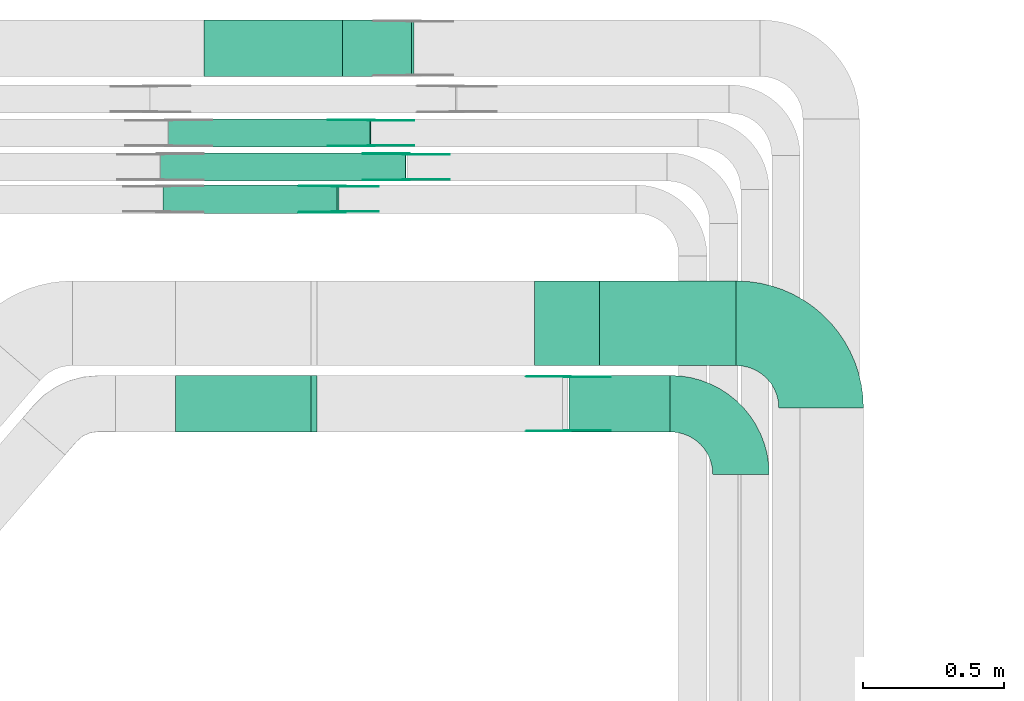
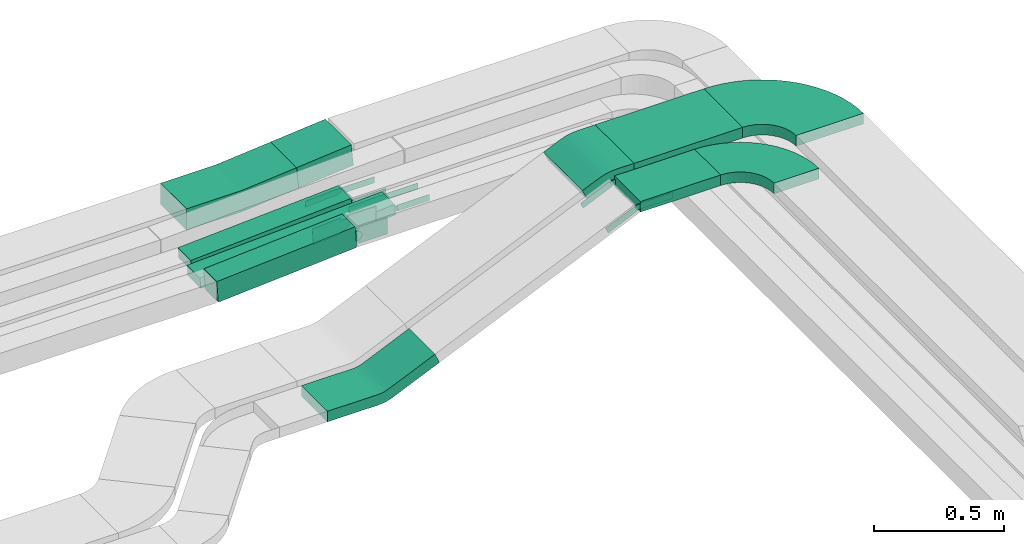
# One storey, part 23 of 31: 21 flow fittings, 6 flow segments.
"""IFC2X3 building model written with IfcOpenShell, lengths in millimetres."""

from ifc_helpers import new_model, entity, si_unit, converted_unit, derived_unit, direction, frame, frame_2d, origin, origin_2d_with_axis, place, context, subcontext, project, spatial, polyline, circle_curve, parameter, trimmed, segment, composite_curve, rectangle, outline, extrude, source, transform, mapped, material, type_object, type_shapes, element, save


model = new_model("IFC2X3")

# Units and contexts
model_context = context("Model", 3, precision=0.01, world=origin(), true_north=direction((6.12303176911189e-17, 1.0)))
body_context = subcontext(model_context, "Body", "Model", "MODEL_VIEW")
ifc_project = project(units=[si_unit("LENGTHUNIT", "METRE", prefix="MILLI"), si_unit("AREAUNIT", "SQUARE_METRE"), si_unit("VOLUMEUNIT", "CUBIC_METRE"), converted_unit("PLANEANGLEUNIT", "DEGREE", entity("IfcRatioMeasure", 0.0174532925199433), si_unit("PLANEANGLEUNIT", "RADIAN"), dimensions=[0, 0, 0, 0, 0, 0, 0]), si_unit("MASSUNIT", "GRAM", prefix="KILO"), derived_unit("MASSDENSITYUNIT", [(si_unit("MASSUNIT", "GRAM", prefix="KILO"), 1), (si_unit("LENGTHUNIT", "METRE"), -3)]), derived_unit("MOMENTOFINERTIAUNIT", [(si_unit("LENGTHUNIT", "METRE"), 4)]), si_unit("TIMEUNIT", "SECOND"), si_unit("FREQUENCYUNIT", "HERTZ"), si_unit("THERMODYNAMICTEMPERATUREUNIT", "DEGREE_CELSIUS"), derived_unit("THERMALTRANSMITTANCEUNIT", [(si_unit("MASSUNIT", "GRAM", prefix="KILO"), 1), (si_unit("THERMODYNAMICTEMPERATUREUNIT", "KELVIN"), -1), (si_unit("TIMEUNIT", "SECOND"), -3)]), derived_unit("VOLUMETRICFLOWRATEUNIT", [(si_unit("LENGTHUNIT", "METRE"), 3), (si_unit("TIMEUNIT", "SECOND"), -1)]), derived_unit("MASSFLOWRATEUNIT", [(si_unit("MASSUNIT", "GRAM", prefix="KILO"), 1), (si_unit("TIMEUNIT", "SECOND"), -1)]), derived_unit("ROTATIONALFREQUENCYUNIT", [(si_unit("TIMEUNIT", "SECOND"), -1)]), si_unit("ELECTRICCURRENTUNIT", "AMPERE"), si_unit("ELECTRICVOLTAGEUNIT", "VOLT"), si_unit("POWERUNIT", "WATT"), si_unit("FORCEUNIT", "NEWTON", prefix="KILO"), si_unit("ILLUMINANCEUNIT", "LUX"), si_unit("LUMINOUSFLUXUNIT", "LUMEN"), si_unit("LUMINOUSINTENSITYUNIT", "CANDELA"), derived_unit("USERDEFINED", [(si_unit("MASSUNIT", "GRAM", prefix="KILO"), -1), (si_unit("LENGTHUNIT", "METRE"), -2), (si_unit("TIMEUNIT", "SECOND"), 3), (si_unit("LUMINOUSFLUXUNIT", "LUMEN"), 1)]), derived_unit("LINEARVELOCITYUNIT", [(si_unit("LENGTHUNIT", "METRE"), 1), (si_unit("TIMEUNIT", "SECOND"), -1)]), si_unit("PRESSUREUNIT", "PASCAL"), derived_unit("USERDEFINED", [(si_unit("LENGTHUNIT", "METRE"), -2), (si_unit("MASSUNIT", "GRAM", prefix="KILO"), 1), (si_unit("TIMEUNIT", "SECOND"), -2)]), derived_unit("LINEARFORCEUNIT", [(si_unit("MASSUNIT", "GRAM", prefix="KILO"), 1), (si_unit("LENGTHUNIT", "METRE"), 1), (si_unit("TIMEUNIT", "SECOND"), -2), (si_unit("LENGTHUNIT", "METRE"), -1)]), derived_unit("PLANARFORCEUNIT", [(si_unit("MASSUNIT", "GRAM", prefix="KILO"), 1), (si_unit("LENGTHUNIT", "METRE"), 1), (si_unit("TIMEUNIT", "SECOND"), -2), (si_unit("LENGTHUNIT", "METRE"), -2)])], contexts=[model_context])

# Site, building, storey
site_placement = place(None, frame((0.0, -0.00077364408347762, 0.0)))
site = spatial("IfcSite", under=ifc_project, at=site_placement, CompositionType="ELEMENT")
building_placement = place(site_placement, origin())
building = spatial("IfcBuilding", under=site, at=building_placement, CompositionType="ELEMENT")
storey_placement = place(building_placement, frame((0.0, 0.0, 15900.0)))
storey = spatial("IfcBuildingStorey", under=building, at=storey_placement, CompositionType="ELEMENT", Elevation=15900.0)

# Flow segments
cable_carrier_segment_type = type_object("IfcCableCarrierSegmentType", PredefinedType="CABLETRAYSEGMENT")
flow_segment_1_placement = place(storey_placement, frame((58933.8883361973, 15999.9939089946, 2637.68567957026)))
element("IfcFlowSegment", 1, at=flow_segment_1_placement, inside=storey, type_object=cable_carrier_segment_type, context=body_context, shape_type="SweptSolid", body=[
    extrude(rectangle(XDim=100.000000000003, YDim=200.000000000002, at=frame_2d((0.0, 0.0), x_axis=(0.0, 1.0))), frame((4.52781513391335, 100.0, 49.7945668734377), z_axis=(0.995891337468723, 0.0, 0.0905563026782642), x_axis=(0.0, 1.0, 0.0)), (0.0, 0.0, 1.0), 245.232289969506),
])
flow_segment_2_placement = place(storey_placement, frame((58297.8986946774, 15514.9939089947, 2617.34283035716)))
element("IfcFlowSegment", 2, at=flow_segment_2_placement, inside=storey, type_object=cable_carrier_segment_type, context=body_context, shape_type="SweptSolid", body=[
    extrude(rectangle(XDim=100.0, YDim=99.9999999999989, at=origin_2d_with_axis()), frame((3.44293413366104, 50.0, 49.8813211989339), z_axis=(0.997626423978678, 0.0, 0.068858682673394), x_axis=(-0.068858682673394, 0.0, 0.997626423978678)), (0.0, 0.0, 1.0), 618.350729393012),
])
flow_segment_3_placement = place(storey_placement, frame((58318.1937005725, 15749.4580000518, 2617.51736519064)))
element("IfcFlowSegment", 3, at=flow_segment_3_placement, inside=storey, type_object=cable_carrier_segment_type, context=body_context, shape_type="SweptSolid", body=[
    extrude(rectangle(XDim=50.0000000000018, YDim=99.9999999999989, at=frame_2d((0.0, 0.0), x_axis=(0.0, 1.0))), frame((1.48822581376082, 50.0, 24.9556643655764), z_axis=(0.998226574623021, 0.0, 0.0595290325504308), x_axis=(0.0, 1.0, 0.0)), (0.0, 0.0, 1.0), 715.803609284785),
])
flow_segment_4_placement = place(storey_placement, frame((58289.554017831, 15629.4580000518, 2617.47740468453)))
element("IfcFlowSegment", 4, at=flow_segment_4_placement, inside=storey, type_object=cable_carrier_segment_type, context=body_context, shape_type="SweptSolid", body=[
    extrude(rectangle(XDim=49.9999999999996, YDim=99.9999999999989, at=frame_2d((0.0, 0.0), x_axis=(0.0, 1.0))), frame((1.22692797513698, 50.0, 24.9698748043255), z_axis=(0.998794992173113, 0.0, 0.0490771190058262), x_axis=(0.0, 1.0, 0.0)), (0.0, 0.0, 1.0), 869.220832372037),
])
flow_segment_5_placement = place(storey_placement, frame((59737.938729634, 14740.0255085138, 3010.0)))
element("IfcFlowSegment", 5, at=flow_segment_5_placement, inside=storey, type_object=cable_carrier_segment_type, context=body_context, shape_type="SweptSolid", body=[
    extrude(rectangle(XDim=357.878829425625, YDim=199.999999999998, at=frame_2d((0.0, -1.08002495835535e-12), x_axis=(1.0, 0.0))), frame((178.939414712821, 100.0, 0.0), z_axis=(0.0, 0.0, 1.0), x_axis=(-1.0, 0.0, 0.0)), (0.0, 0.0, 1.0), 50.0000000000016),
])
flow_segment_6_placement = place(storey_placement, frame((59845.664235863, 14975.0255085139, 3010.0)))
element("IfcFlowSegment", 6, at=flow_segment_6_placement, inside=storey, type_object=cable_carrier_segment_type, context=body_context, shape_type="SweptSolid", body=[
    extrude(rectangle(XDim=484.15332319662, YDim=300.000000000001, at=frame_2d((-4.33431068813661e-12, 1.08002495835535e-12), x_axis=(1.0, 0.0))), frame((242.076661598306, 150.0, 0.0), z_axis=(0.0, 0.0, 1.0), x_axis=(-1.0, 0.0, 0.0)), (0.0, 0.0, 1.0), 50.0000000000016),
])

# Flow fittings
ifc_material_1 = material(Name="G")
cable_carrier_fitting_type_1 = type_object("IfcCableCarrierFittingType", PredefinedType="NOTDEFINED", material=ifc_material_1)
shared_shape_1 = source(origin(), body_context, "Body", "SweptSolid", [
    extrude(outline(composite_curve([segment(trimmed(circle_curve(frame_2d((-44.5901162790698, 0.0), x_axis=(1.0, 0.0)), 12.5), [parameter(90.0000000000007)], [parameter(270.0)], True, "PARAMETER"), True, "CONTINUOUS"), segment(polyline([(-44.5901162790697, -12.5), (-33.0901162790698, -12.5)]), True, "CONTINUOUS"), segment(polyline([(-33.0901162790698, -12.5), (-31.2296511627907, -14.5)]), True, "CONTINUOUS"), segment(polyline([(-31.2296511627907, -14.5), (108.90988372093, -14.5)]), True, "CONTINUOUS"), segment(polyline([(108.90988372093, -14.5), (108.90988372093, 14.5)]), True, "CONTINUOUS"), segment(polyline([(108.90988372093, 14.5), (-31.2296511627907, 14.5)]), True, "CONTINUOUS"), segment(polyline([(-31.2296511627907, 14.5), (-33.0901162790698, 12.5)]), True, "CONTINUOUS"), segment(polyline([(-33.0901162790698, 12.5), (-44.5901162790699, 12.5)]), True, "CONTINUOUS")], self_intersect=False)), frame((44.5901162790698, 0.0, 0.0), z_axis=(0.0, 0.0, -1.0), x_axis=(1.0, 0.0, 0.0)), (0.0, 0.0, -1.0), 2.0),
])
type_shapes(cable_carrier_fitting_type_1, [shared_shape_1])
for number, where, z_axis, x_axis in (
    (7, (59036.0767428681, 15753.9980000417, 2685.19508428163), (0.0, -1.0, 0.0), (-0.998226574623013, 0.0, -0.0595290325505655)),
    (8, (59160.6643444784, 15633.9980000417, 2685.19015606757), (0.0, -1.0, 0.0), (-0.998794992173109, 0.0, -0.0490771190058922)),
    (9, (59730.8175590596, 14744.5655085037, 3035.0), (0.0, -1.0, 0.0), (-0.914695360334433, 0.0, -0.404144030987297)),
):
    element("IfcFlowFitting", number, at=place(storey_placement, frame(where, z_axis=z_axis, x_axis=x_axis)), inside=storey, type_object=cable_carrier_fitting_type_1, material=ifc_material_1, context=body_context, shape_type="MappedRepresentation", body=[
        mapped(shared_shape_1, transform((0.0, 0.0, 0.0), scale=1.0)),
    ])
cable_carrier_fitting_type_2 = type_object("IfcCableCarrierFittingType", PredefinedType="NOTDEFINED", material=ifc_material_1)
shared_shape_2 = source(origin(), body_context, "Body", "SweptSolid", [
    extrude(outline(composite_curve([segment(trimmed(circle_curve(frame_2d((-44.5901162790697, 0.0), x_axis=(1.0, 0.0)), 12.5), [parameter(90.0000000000007)], [parameter(270.0)], True, "PARAMETER"), True, "CONTINUOUS"), segment(polyline([(-44.5901162790697, -12.5), (-33.0901162790697, -12.5)]), True, "CONTINUOUS"), segment(polyline([(-33.0901162790697, -12.5), (-31.2296511627907, -14.5)]), True, "CONTINUOUS"), segment(polyline([(-31.2296511627907, -14.5), (108.90988372093, -14.5)]), True, "CONTINUOUS"), segment(polyline([(108.90988372093, -14.5), (108.90988372093, 14.5)]), True, "CONTINUOUS"), segment(polyline([(108.90988372093, 14.5), (-31.2296511627907, 14.5)]), True, "CONTINUOUS"), segment(polyline([(-31.2296511627907, 14.5), (-33.0901162790698, 12.5)]), True, "CONTINUOUS"), segment(polyline([(-33.0901162790698, 12.5), (-44.5901162790699, 12.5)]), True, "CONTINUOUS")], self_intersect=False)), frame((44.5901162790697, 0.0, 0.0)), (0.0, 0.0, 1.0), 2.0),
])
type_shapes(cable_carrier_fitting_type_2, [shared_shape_2])
for number, where, z_axis, x_axis in (
    (10, (59036.0767428681, 15844.918000062, 2685.19508428164), (0.0, 1.0, 0.0), (-0.998226574623013, 0.0, -0.0595290325505655)),
    (11, (59160.6643444784, 15724.918000062, 2685.19015606758), (0.0, 1.0, 0.0), (-0.998794992173109, 0.0, -0.0490771190058922)),
    (12, (59730.8175590596, 14935.485508524, 3035.0), (0.0, 1.0, 0.0), (-0.914695360334433, 0.0, -0.404144030987297)),
):
    element("IfcFlowFitting", number, at=place(storey_placement, frame(where, z_axis=z_axis, x_axis=x_axis)), inside=storey, type_object=cable_carrier_fitting_type_2, material=ifc_material_1, context=body_context, shape_type="MappedRepresentation", body=[
        mapped(shared_shape_2, transform((0.0, 0.0, 0.0), scale=1.0)),
    ])
cable_carrier_fitting_type_3 = type_object("IfcCableCarrierFittingType", PredefinedType="NOTDEFINED", material=ifc_material_1)
shared_shape_3 = source(origin(), body_context, "Body", "SweptSolid", [
    extrude(outline(composite_curve([segment(trimmed(circle_curve(frame_2d((-44.5901162790698, 0.0), x_axis=(1.0, 0.0)), 12.5), [parameter(90.0000000000007)], [parameter(270.0)], True, "PARAMETER"), True, "CONTINUOUS"), segment(polyline([(-44.5901162790697, -12.5), (-33.0901162790698, -12.5)]), True, "CONTINUOUS"), segment(polyline([(-33.0901162790698, -12.5), (-31.2296511627907, -14.5)]), True, "CONTINUOUS"), segment(polyline([(-31.2296511627907, -14.5), (108.90988372093, -14.5)]), True, "CONTINUOUS"), segment(polyline([(108.90988372093, -14.5), (108.90988372093, 14.5)]), True, "CONTINUOUS"), segment(polyline([(108.90988372093, 14.5), (-31.2296511627907, 14.5)]), True, "CONTINUOUS"), segment(polyline([(-31.2296511627907, 14.5), (-33.0901162790698, 12.5)]), True, "CONTINUOUS"), segment(polyline([(-33.0901162790698, 12.5), (-44.5901162790699, 12.5)]), True, "CONTINUOUS")], self_intersect=False)), frame((44.5901162790698, 0.0, 0.0), z_axis=(0.0, 0.0, -1.0), x_axis=(1.0, 0.0, 0.0)), (0.0, 0.0, -1.0), 2.0),
])
type_shapes(cable_carrier_fitting_type_3, [shared_shape_3])
for number, where, z_axis, x_axis in (
    (13, (59036.0767428681, 15842.918000062, 2685.19508428163), (0.0, 1.0, 0.0), (1.0, 0.0, 0.0)),
    (14, (59160.6643444783, 15722.918000062, 2685.19015606757), (0.0, 1.0, 0.0), (1.0, 0.0, 0.0)),
    (15, (59730.8175590596, 14933.485508524, 3035.0), (0.0, 1.0, 0.0), (1.0, 0.0, 0.0)),
):
    element("IfcFlowFitting", number, at=place(storey_placement, frame(where, z_axis=z_axis, x_axis=x_axis)), inside=storey, type_object=cable_carrier_fitting_type_3, material=ifc_material_1, context=body_context, shape_type="MappedRepresentation", body=[
        mapped(shared_shape_3, transform((0.0, 0.0, 0.0), scale=1.0)),
    ])
cable_carrier_fitting_type_4 = type_object("IfcCableCarrierFittingType", PredefinedType="NOTDEFINED", material=ifc_material_1)
shared_shape_4 = source(origin(), body_context, "Body", "SweptSolid", [
    extrude(outline(composite_curve([segment(trimmed(circle_curve(frame_2d((-44.5901162790697, 0.0), x_axis=(1.0, 0.0)), 12.5), [parameter(90.0000000000007)], [parameter(270.0)], True, "PARAMETER"), True, "CONTINUOUS"), segment(polyline([(-44.5901162790697, -12.5), (-33.0901162790697, -12.5)]), True, "CONTINUOUS"), segment(polyline([(-33.0901162790697, -12.5), (-31.2296511627907, -14.5)]), True, "CONTINUOUS"), segment(polyline([(-31.2296511627907, -14.5), (108.90988372093, -14.5)]), True, "CONTINUOUS"), segment(polyline([(108.90988372093, -14.5), (108.90988372093, 14.5)]), True, "CONTINUOUS"), segment(polyline([(108.90988372093, 14.5), (-31.2296511627907, 14.5)]), True, "CONTINUOUS"), segment(polyline([(-31.2296511627907, 14.5), (-33.0901162790698, 12.5)]), True, "CONTINUOUS"), segment(polyline([(-33.0901162790698, 12.5), (-44.5901162790699, 12.5)]), True, "CONTINUOUS")], self_intersect=False)), frame((44.5901162790697, 0.0, 0.0)), (0.0, 0.0, 1.0), 2.0),
])
type_shapes(cable_carrier_fitting_type_4, [shared_shape_4])
for number, where, z_axis, x_axis in (
    (16, (59036.0767428681, 15755.9980000417, 2685.19508428163), (0.0, -1.0, 0.0), (1.0, 0.0, 0.0)),
    (17, (59160.6643444783, 15635.9980000417, 2685.19015606757), (0.0, -1.0, 0.0), (1.0, 0.0, 0.0)),
    (18, (59730.8175590596, 14746.5655085037, 3035.0), (0.0, -1.0, 0.0), (1.0, 0.0, 0.0)),
):
    element("IfcFlowFitting", number, at=place(storey_placement, frame(where, z_axis=z_axis, x_axis=x_axis)), inside=storey, type_object=cable_carrier_fitting_type_4, material=ifc_material_1, context=body_context, shape_type="MappedRepresentation", body=[
        mapped(shared_shape_4, transform((0.0, 0.0, 0.0), scale=1.0)),
    ])
ifc_material_2 = material()
cable_carrier_fitting_type_5 = type_object("IfcCableCarrierFittingType", Name="470_DKC_S5_Variable Angle Elbow 0-45:-", PredefinedType="NOTDEFINED", material=ifc_material_2)
shared_shape_5 = source(origin(), body_context, "Body", "SweptSolid", [
    extrude(outline(composite_curve([segment(polyline([(-150.749999999996, -300.250000000003), (-149.749999999994, -300.250000000003)]), True, "CONTINUOUS"), segment(trimmed(circle_curve(frame_2d((-149.750000000002, 149.749999999997), x_axis=(0.0, -1.0)), 450.0), [parameter(0.0)], [parameter(90.0000000000001)], True, "PARAMETER"), True, "CONTINUOUS"), segment(polyline([(300.249999999997, 149.750000000005), (300.249999999997, 150.750000000004)]), True, "CONTINUOUS"), segment(polyline([(300.249999999997, 150.750000000003), (0.249999999997449, 150.750000000002)]), True, "CONTINUOUS"), segment(polyline([(0.249999999997449, 150.750000000002), (0.249999999997438, 149.75)]), True, "CONTINUOUS"), segment(trimmed(circle_curve(frame_2d((-149.750000000002, 149.749999999997), x_axis=(0.0, -1.0)), 150.0), [parameter(0.0)], [parameter(90.0000000000001)], True, "PARAMETER"), False, "CONTINUOUS"), segment(polyline([(-149.749999999999, -0.250000000002818), (-150.750000000001, -0.250000000002835)]), True, "CONTINUOUS"), segment(polyline([(-150.750000000001, -0.250000000002835), (-150.749999999996, -300.250000000003)]), True, "CONTINUOUS")], self_intersect=False)), frame((-150.249999999991, 150.249999999992, -25.0)), (0.0, 0.0, 1.0), 49.9999999999974),
])
type_shapes(cable_carrier_fitting_type_5, [shared_shape_5])
flow_fitting_1_placement = place(storey_placement, frame((60630.8175590596, 15125.0255085138, 3035.0), z_axis=(0.0, 0.0, 1.0), x_axis=(0.0, 1.0, 0.0)))
element("IfcFlowFitting", 19, at=flow_fitting_1_placement, inside=storey, type_object=cable_carrier_fitting_type_5, material=ifc_material_2, Name="470_DKC_S5_Variable Angle Elbow 0-45:-", ObjectType="470_DKC_S5_Variable Angle Elbow 0-45:-", context=body_context, shape_type="MappedRepresentation", body=[
    mapped(shared_shape_5, transform((0.0, 0.0, 0.0), scale=1.0)),
])
cable_carrier_fitting_type_6 = type_object("IfcCableCarrierFittingType", Name="470_DKC_S5_Variable Angle Elbow 0-45:-", PredefinedType="NOTDEFINED", material=ifc_material_2)
shared_shape_6 = source(origin(), body_context, "Body", "SweptSolid", [
    extrude(outline(composite_curve([segment(polyline([(-125.750000000004, -225.249999999998), (-124.750000000003, -225.249999999998)]), True, "CONTINUOUS"), segment(trimmed(circle_curve(frame_2d((-124.749999999998, 124.750000000002), x_axis=(0.0, -1.0)), 350.0), [parameter(0.0)], [parameter(90.0)], True, "PARAMETER"), True, "CONTINUOUS"), segment(polyline([(225.250000000002, 124.749999999996), (225.250000000002, 125.749999999995)]), True, "CONTINUOUS"), segment(polyline([(225.250000000002, 125.749999999995), (25.2500000000021, 125.750000000001)]), True, "CONTINUOUS"), segment(polyline([(25.2500000000021, 125.750000000001), (25.2500000000021, 124.749999999999)]), True, "CONTINUOUS"), segment(trimmed(circle_curve(frame_2d((-124.749999999998, 124.750000000002), x_axis=(0.0, -1.0)), 150.0), [parameter(0.0)], [parameter(90.0)], True, "PARAMETER"), False, "CONTINUOUS"), segment(polyline([(-124.75, -25.2499999999979), (-125.750000000001, -25.2499999999979)]), True, "CONTINUOUS"), segment(polyline([(-125.750000000001, -25.2499999999979), (-125.750000000004, -225.249999999998)]), True, "CONTINUOUS")], self_intersect=False)), frame((-125.249999999991, 125.249999999992, -25.0)), (0.0, 0.0, 1.0), 50.000000000001),
])
type_shapes(cable_carrier_fitting_type_6, [shared_shape_6])
flow_fitting_2_placement = place(storey_placement, frame((60346.8175590596, 14840.0255085138, 3035.0), z_axis=(0.0, 0.0, 1.0), x_axis=(0.0, 1.0, 0.0)))
element("IfcFlowFitting", 20, at=flow_fitting_2_placement, inside=storey, type_object=cable_carrier_fitting_type_6, material=ifc_material_2, Name="470_DKC_S5_Variable Angle Elbow 0-45:-", ObjectType="470_DKC_S5_Variable Angle Elbow 0-45:-", context=body_context, shape_type="MappedRepresentation", body=[
    mapped(shared_shape_6, transform((0.0, 0.0, 0.0), scale=1.0)),
])
cable_carrier_fitting_type_7 = type_object("IfcCableCarrierFittingType", PredefinedType="NOTDEFINED", material=ifc_material_1)
shared_shape_7 = source(origin(), body_context, "Body", "SweptSolid", [
    extrude(outline(composite_curve([segment(trimmed(circle_curve(frame_2d((-41.4651162790697, 0.0), x_axis=(1.0, 0.0)), 25.0), [parameter(90.0000000000007)], [parameter(270.0)], True, "PARAMETER"), True, "CONTINUOUS"), segment(polyline([(-41.4651162790697, -25.0), (-29.9651162790697, -25.0)]), True, "CONTINUOUS"), segment(polyline([(-29.9651162790697, -25.0), (-28.1046511627907, -38.5)]), True, "CONTINUOUS"), segment(polyline([(-28.1046511627907, -38.5), (99.5348837209303, -38.5)]), True, "CONTINUOUS"), segment(polyline([(99.5348837209303, -38.5), (99.5348837209303, 38.5)]), True, "CONTINUOUS"), segment(polyline([(99.5348837209303, 38.5), (-28.1046511627907, 38.5)]), True, "CONTINUOUS"), segment(polyline([(-28.1046511627907, 38.5), (-29.9651162790697, 25.0)]), True, "CONTINUOUS"), segment(polyline([(-29.9651162790697, 25.0), (-41.46511627907, 25.0)]), True, "CONTINUOUS")], self_intersect=False)), frame((41.4651162790697, 0.0, 0.0), z_axis=(0.0, 0.0, -1.0), x_axis=(1.0, 0.0, 0.0)), (0.0, 0.0, -1.0), 2.0),
])
type_shapes(cable_carrier_fitting_type_7, [shared_shape_7])
flow_fitting_3_placement = place(storey_placement, frame((58921.0792575167, 15519.5339089845, 2710.0), z_axis=(0.0, -1.0, 0.0), x_axis=(-0.997626423978682, 0.0, -0.0688586826733382)))
element("IfcFlowFitting", 21, at=flow_fitting_3_placement, inside=storey, type_object=cable_carrier_fitting_type_7, material=ifc_material_1, context=body_context, shape_type="MappedRepresentation", body=[
    mapped(shared_shape_7, transform((0.0, 0.0, 0.0), scale=1.0)),
])
cable_carrier_fitting_type_8 = type_object("IfcCableCarrierFittingType", PredefinedType="NOTDEFINED", material=ifc_material_1)
shared_shape_8 = source(origin(), body_context, "Body", "SweptSolid", [
    extrude(outline(composite_curve([segment(trimmed(circle_curve(frame_2d((-41.4651162790697, 0.0), x_axis=(1.0, 0.0)), 25.0), [parameter(90.0000000000007)], [parameter(270.0)], True, "PARAMETER"), True, "CONTINUOUS"), segment(polyline([(-41.4651162790697, -25.0), (-29.9651162790697, -25.0)]), True, "CONTINUOUS"), segment(polyline([(-29.9651162790697, -25.0), (-28.1046511627907, -38.5)]), True, "CONTINUOUS"), segment(polyline([(-28.1046511627907, -38.5), (99.5348837209303, -38.5)]), True, "CONTINUOUS"), segment(polyline([(99.5348837209303, -38.5), (99.5348837209303, 38.5)]), True, "CONTINUOUS"), segment(polyline([(99.5348837209303, 38.5), (-28.1046511627907, 38.5)]), True, "CONTINUOUS"), segment(polyline([(-28.1046511627907, 38.5), (-29.9651162790697, 25.0)]), True, "CONTINUOUS"), segment(polyline([(-29.9651162790697, 25.0), (-41.46511627907, 25.0)]), True, "CONTINUOUS")], self_intersect=False)), frame((41.4651162790697, 0.0, 0.0)), (0.0, 0.0, 1.0), 2.0),
])
type_shapes(cable_carrier_fitting_type_8, [shared_shape_8])
flow_fitting_4_placement = place(storey_placement, frame((58921.0792575167, 15610.4539090048, 2710.0), z_axis=(0.0, 1.0, 0.0), x_axis=(-0.997626423978682, 0.0, -0.0688586826733382)))
element("IfcFlowFitting", 22, at=flow_fitting_4_placement, inside=storey, type_object=cable_carrier_fitting_type_8, material=ifc_material_1, context=body_context, shape_type="MappedRepresentation", body=[
    mapped(shared_shape_8, transform((0.0, 0.0, 0.0), scale=1.0)),
])
cable_carrier_fitting_type_9 = type_object("IfcCableCarrierFittingType", PredefinedType="NOTDEFINED", material=ifc_material_1)
shared_shape_9 = source(origin(), body_context, "Body", "SweptSolid", [
    extrude(outline(composite_curve([segment(trimmed(circle_curve(frame_2d((-41.4651162790697, 0.0), x_axis=(1.0, 0.0)), 25.0), [parameter(90.0000000000007)], [parameter(270.0)], True, "PARAMETER"), True, "CONTINUOUS"), segment(polyline([(-41.4651162790697, -25.0), (-29.9651162790697, -25.0)]), True, "CONTINUOUS"), segment(polyline([(-29.9651162790697, -25.0), (-28.1046511627907, -38.5)]), True, "CONTINUOUS"), segment(polyline([(-28.1046511627907, -38.5), (99.5348837209303, -38.5)]), True, "CONTINUOUS"), segment(polyline([(99.5348837209303, -38.5), (99.5348837209303, 38.5)]), True, "CONTINUOUS"), segment(polyline([(99.5348837209303, 38.5), (-28.1046511627907, 38.5)]), True, "CONTINUOUS"), segment(polyline([(-28.1046511627907, 38.5), (-29.9651162790697, 25.0)]), True, "CONTINUOUS"), segment(polyline([(-29.9651162790697, 25.0), (-41.46511627907, 25.0)]), True, "CONTINUOUS")], self_intersect=False)), frame((41.4651162790697, 0.0, 0.0), z_axis=(0.0, 0.0, -1.0), x_axis=(1.0, 0.0, 0.0)), (0.0, 0.0, -1.0), 2.0),
])
type_shapes(cable_carrier_fitting_type_9, [shared_shape_9])
flow_fitting_5_placement = place(storey_placement, frame((58921.0792575167, 15608.4539090048, 2710.0), z_axis=(0.0, 1.0, 0.0), x_axis=(1.0, 0.0, 0.0)))
element("IfcFlowFitting", 23, at=flow_fitting_5_placement, inside=storey, type_object=cable_carrier_fitting_type_9, material=ifc_material_1, context=body_context, shape_type="MappedRepresentation", body=[
    mapped(shared_shape_9, transform((0.0, 0.0, 0.0), scale=1.0)),
])
cable_carrier_fitting_type_10 = type_object("IfcCableCarrierFittingType", PredefinedType="NOTDEFINED", material=ifc_material_1)
shared_shape_10 = source(origin(), body_context, "Body", "SweptSolid", [
    extrude(outline(composite_curve([segment(trimmed(circle_curve(frame_2d((-41.4651162790697, 0.0), x_axis=(1.0, 0.0)), 25.0), [parameter(90.0000000000007)], [parameter(270.0)], True, "PARAMETER"), True, "CONTINUOUS"), segment(polyline([(-41.4651162790697, -25.0), (-29.9651162790697, -25.0)]), True, "CONTINUOUS"), segment(polyline([(-29.9651162790697, -25.0), (-28.1046511627907, -38.5)]), True, "CONTINUOUS"), segment(polyline([(-28.1046511627907, -38.5), (99.5348837209303, -38.5)]), True, "CONTINUOUS"), segment(polyline([(99.5348837209303, -38.5), (99.5348837209303, 38.5)]), True, "CONTINUOUS"), segment(polyline([(99.5348837209303, 38.5), (-28.1046511627907, 38.5)]), True, "CONTINUOUS"), segment(polyline([(-28.1046511627907, 38.5), (-29.9651162790697, 25.0)]), True, "CONTINUOUS"), segment(polyline([(-29.9651162790697, 25.0), (-41.46511627907, 25.0)]), True, "CONTINUOUS")], self_intersect=False)), frame((41.4651162790697, 0.0, 0.0)), (0.0, 0.0, 1.0), 2.0),
])
type_shapes(cable_carrier_fitting_type_10, [shared_shape_10])
flow_fitting_6_placement = place(storey_placement, frame((58921.0792575167, 15521.5339089845, 2710.0), z_axis=(0.0, -1.0, 0.0), x_axis=(1.0, 0.0, 0.0)))
element("IfcFlowFitting", 24, at=flow_fitting_6_placement, inside=storey, type_object=cable_carrier_fitting_type_10, material=ifc_material_1, context=body_context, shape_type="MappedRepresentation", body=[
    mapped(shared_shape_10, transform((0.0, 0.0, 0.0), scale=1.0)),
])
cable_carrier_fitting_type_11 = type_object("IfcCableCarrierFittingType", Name="470_DKC_S5_CS 90 internal vertical angle:-", PredefinedType="NOTDEFINED", material=ifc_material_2)
shared_shape_11 = source(origin(), body_context, "Body", "SweptSolid", [
    extrude(outline(composite_curve([segment(polyline([(-247.983392623155, -55.78954394036), (-7.22359478083479, -55.78954394036)]), True, "CONTINUOUS"), segment(trimmed(circle_curve(frame_2d((-7.22359478083515, 159.210456059639), x_axis=(0.0, -1.0)), 214.999999999999), [parameter(0.0)], [parameter(5.19561157426616)], True, "PARAMETER"), True, "CONTINUOUS"), segment(polyline([(12.2460102949534, -54.906181496139), (252.016607376845, -33.1038643700154)]), True, "CONTINUOUS"), segment(polyline([(252.016607376845, -33.1038643700154), (242.960977109036, 66.4852693768588)]), True, "CONTINUOUS"), segment(polyline([(242.960977109037, 66.4852693768588), (3.19038002714467, 44.6829522507353)]), True, "CONTINUOUS"), segment(trimmed(circle_curve(frame_2d((-7.22359478083515, 159.210456059639), x_axis=(0.0, -1.0)), 114.999999999999), [parameter(0.0)], [parameter(5.19561157426616)], True, "PARAMETER"), False, "CONTINUOUS"), segment(polyline([(-7.22359478083478, 44.2104560596403), (-247.983392623155, 44.2104560596403)]), True, "CONTINUOUS"), segment(polyline([(-247.983392623155, 44.2104560596403), (-247.983392623155, -55.78954394036)]), True, "CONTINUOUS")], self_intersect=False)), frame((-0.262679477369824, 5.78954394035265, -100.0)), (0.0, 0.0, 1.0), 200.0),
])
type_shapes(cable_carrier_fitting_type_11, [shared_shape_11])
flow_fitting_7_placement = place(storey_placement, frame((58691.1900385657, 16099.9939089946, 2665.0), z_axis=(0.0, -1.0, 0.0), x_axis=(1.0, 0.0, 0.0)))
element("IfcFlowFitting", 25, at=flow_fitting_7_placement, inside=storey, type_object=cable_carrier_fitting_type_11, material=ifc_material_2, Name="470_DKC_S5_CS 90 internal vertical angle:-", ObjectType="470_DKC_S5_CS 90 internal vertical angle:-", context=body_context, shape_type="MappedRepresentation", body=[
    mapped(shared_shape_11, transform((0.0, 0.0, 0.0), scale=1.0)),
])
cable_carrier_fitting_type_12 = type_object("IfcCableCarrierFittingType", Name="470_DKC_S5_CD 90 external vertical angle:-", PredefinedType="NOTDEFINED", material=ifc_material_2)
shared_shape_12 = source(origin(), body_context, "Body", "SweptSolid", [
    extrude(outline(composite_curve([segment(polyline([(-111.654704576314, -40.1224661133865), (-31.635377592761, -40.1224661133865)]), True, "CONTINUOUS"), segment(trimmed(circle_curve(frame_2d((-31.6353775927612, 149.877533886612), x_axis=(0.0, -1.0)), 189.999999999999), [parameter(0.0)], [parameter(23.8374988354048)], True, "PARAMETER"), True, "CONTINUOUS"), segment(polyline([(45.1519882947282, -23.9145845769716), (118.345295423686, 8.42474878701124)]), True, "CONTINUOUS"), segment(polyline([(118.345295423686, 8.42474878701124), (98.1380938743463, 54.1595168037444)]), True, "CONTINUOUS"), segment(polyline([(98.1380938743463, 54.1595168037444), (24.9447867453887, 21.8201834397615)]), True, "CONTINUOUS"), segment(trimmed(circle_curve(frame_2d((-31.6353775927612, 149.877533886612), x_axis=(0.0, -1.0)), 139.999999999999), [parameter(0.0)], [parameter(23.8374988354048)], True, "PARAMETER"), False, "CONTINUOUS"), segment(polyline([(-31.635377592761, 9.87753388661379), (-111.654704576314, 9.87753388661378)]), True, "CONTINUOUS"), segment(polyline([(-111.654704576314, 9.87753388661378), (-111.654704576314, -40.1224661133865)]), True, "CONTINUOUS")], self_intersect=False)), frame((-3.19197222708058, 15.1224661133793, -150.0)), (0.0, 0.0, 1.0), 300.0),
])
type_shapes(cable_carrier_fitting_type_12, [shared_shape_12])
flow_fitting_8_placement = place(storey_placement, frame((59730.8175590596, 15125.0255085139, 3035.0), z_axis=(0.0, -1.0, 0.0), x_axis=(-1.0, 0.0, 0.0)))
element("IfcFlowFitting", 26, at=flow_fitting_8_placement, inside=storey, type_object=cable_carrier_fitting_type_12, material=ifc_material_2, Name="470_DKC_S5_CD 90 external vertical angle:-", ObjectType="470_DKC_S5_CD 90 external vertical angle:-", context=body_context, shape_type="MappedRepresentation", body=[
    mapped(shared_shape_12, transform((0.0, 0.0, 0.0), scale=1.0)),
])
cable_carrier_fitting_type_13 = type_object("IfcCableCarrierFittingType", Name="470_DKC_S5_CS 90 internal vertical angle:-", PredefinedType="NOTDEFINED", material=ifc_material_2)
shared_shape_13 = source(origin(), body_context, "Body", "SweptSolid", [
    extrude(outline(composite_curve([segment(polyline([(-249.7745398812, -53.8368643145496), (-23.4637419005688, -53.8368643145496)]), True, "CONTINUOUS"), segment(trimmed(circle_curve(frame_2d((-23.4637419005691, 111.163135685449), x_axis=(0.0, -1.0)), 164.999999999999), [parameter(0.0)], [parameter(23.8374988354359)], True, "PARAMETER"), True, "CONTINUOUS"), segment(polyline([(43.2200232123325, -39.761598769732), (250.2254601188, 51.7005593821088)]), True, "CONTINUOUS"), segment(polyline([(250.2254601188, 51.7005593821088), (230.018258569436, 97.435327398831)]), True, "CONTINUOUS"), segment(polyline([(230.018258569436, 97.435327398831), (23.0128216629682, 5.97316924699014)]), True, "CONTINUOUS"), segment(trimmed(circle_curve(frame_2d((-23.4637419005691, 111.163135685449), x_axis=(0.0, -1.0)), 114.999999999999), [parameter(0.0)], [parameter(23.8374988354359)], True, "PARAMETER"), False, "CONTINUOUS"), segment(polyline([(-23.4637419005688, -3.83686431454932), (-249.7745398812, -3.83686431454932)]), True, "CONTINUOUS"), segment(polyline([(-249.7745398812, -3.83686431454932), (-249.7745398812, -53.8368643145496)]), True, "CONTINUOUS")], self_intersect=False)), frame((-6.0867367344865, 28.8368643145423, -100.0)), (0.0, 0.0, 1.0), 200.0),
])
type_shapes(cable_carrier_fitting_type_13, [shared_shape_13])
flow_fitting_9_placement = place(storey_placement, frame((58599.1722912774, 14840.0255085139, 2535.0), z_axis=(0.0, 1.0, 0.0), x_axis=(-0.914695360334433, 0.0, -0.404144030987297)))
element("IfcFlowFitting", 27, at=flow_fitting_9_placement, inside=storey, type_object=cable_carrier_fitting_type_13, material=ifc_material_2, Name="470_DKC_S5_CS 90 internal vertical angle:-", ObjectType="470_DKC_S5_CS 90 internal vertical angle:-", context=body_context, shape_type="MappedRepresentation", body=[
    mapped(shared_shape_13, transform((0.0, 0.0, 0.0), scale=1.0)),
])

save(model, "model.ifc")
